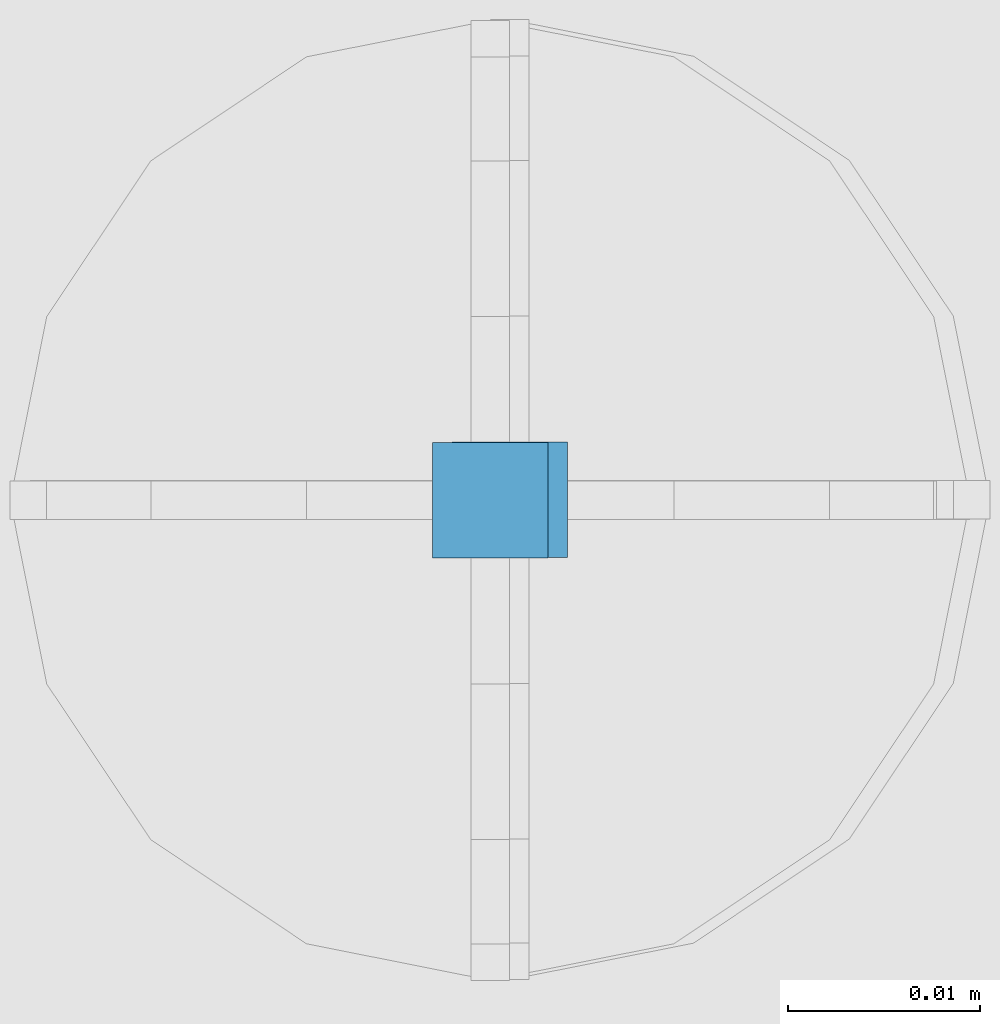
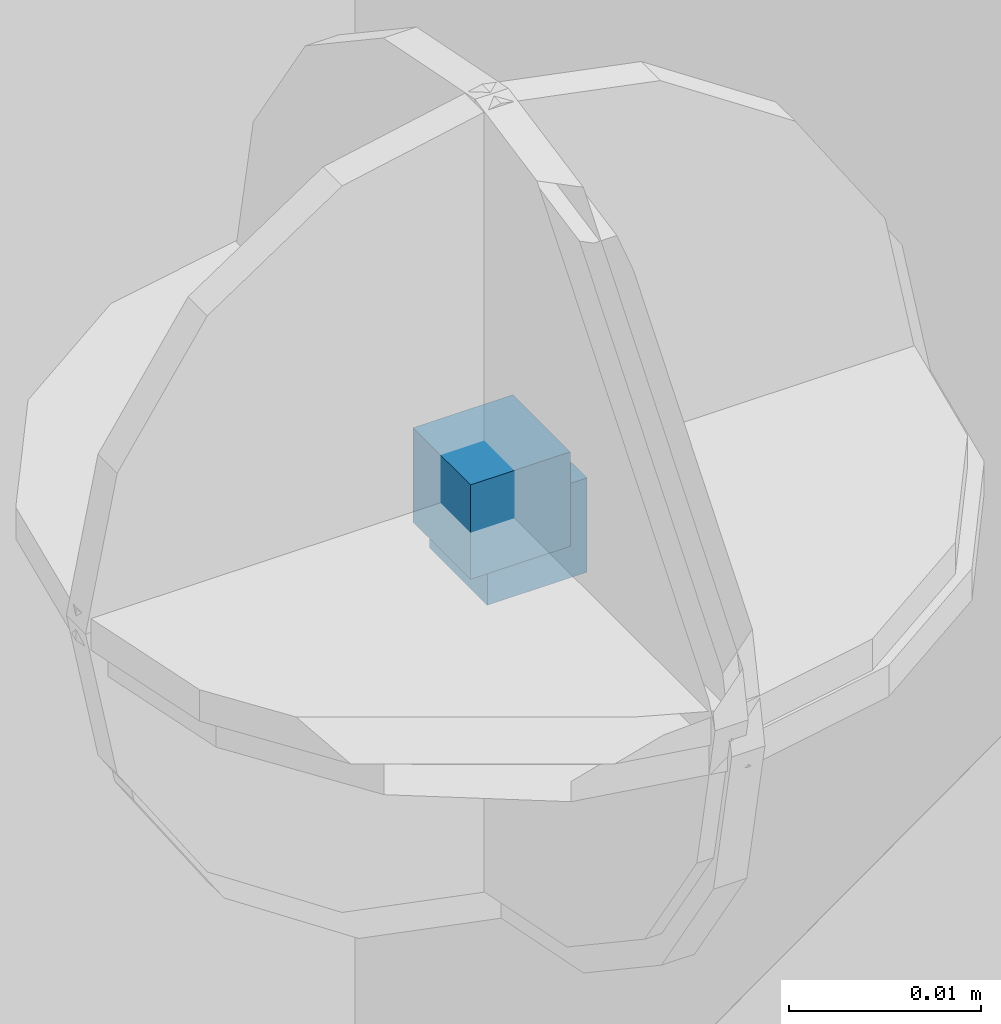
# One storey, part 75 of 349: 2 columns, 3 elements without a shape of their own.
"""IFC2X3 building model written with IfcOpenShell, lengths in millimetres."""

from ifc_helpers import new_model, si_unit, frame, origin_with_axes, place, context, subcontext, project, spatial, faceted_brep, material, type_object, element, aggregate, save


model = new_model("IFC2X3")

# Units and contexts
model_context = context("Model", 3, precision=1e-05, world=origin_with_axes())
body_context = subcontext(model_context, "Body", "Model", "MODEL_VIEW")
ifc_project = project(units=[si_unit("LENGTHUNIT", "METRE", prefix="MILLI"), si_unit("AREAUNIT", "SQUARE_METRE"), si_unit("VOLUMEUNIT", "CUBIC_METRE"), si_unit("MASSUNIT", "GRAM", prefix="KILO"), si_unit("TIMEUNIT", "SECOND"), si_unit("PLANEANGLEUNIT", "RADIAN"), si_unit("SOLIDANGLEUNIT", "STERADIAN"), si_unit("THERMODYNAMICTEMPERATUREUNIT", "DEGREE_CELSIUS"), si_unit("LUMINOUSINTENSITYUNIT", "LUMEN")], contexts=[model_context])

# Site, building, storey
site_placement = place(None, origin_with_axes())
site = spatial("IfcSite", under=ifc_project, at=site_placement, CompositionType="ELEMENT")
building_placement = place(site_placement, origin_with_axes())
building = spatial("IfcBuilding", under=site, at=building_placement, CompositionType="ELEMENT")
storey_placement = place(building_placement, origin_with_axes())
storey = spatial("IfcBuildingStorey", under=building, at=storey_placement, Name="4", CompositionType="ELEMENT", Elevation=0.0)

# Assemblies, columns
assembly_1_placement = place(storey_placement, origin_with_axes())
assembly_1 = element("IfcElementAssembly", 1, at=assembly_1_placement, inside=storey, AssemblyPlace="NOTDEFINED", PredefinedType="REINFORCEMENT_UNIT")
assembly_2_placement = place(assembly_1_placement, origin_with_axes())
assembly_2 = element("IfcElementAssembly", 2, at=assembly_2_placement, Name="Steel Assembly", AssemblyPlace="NOTDEFINED", PredefinedType="RIGID_FRAME")
ifc_material = material(Name="STEEL/Steel_Undefined")
column_type = type_object("IfcColumnType", PredefinedType="NOTDEFINED")
column_1_placement = place(assembly_2_placement, frame((19805.3672816511, 20613.5564077389, 93731.5262892386), z_axis=(0.0, -1.0, 0.0), x_axis=(0.0, 0.0, 1.0)))
column_1 = element("IfcColumn", 3, at=column_1_placement, type_object=column_type, material=ifc_material, Name="PP", context=body_context, shape_type="Brep", body=[
    faceted_brep([(0.0, 3.0, -3.0), (0.0, 2.99999999999636, 3.0), (6.0, 2.99999999999636, 3.0), (6.0, 3.0, -3.0), (0.0, -3.00000000000364, 3.0), (6.0, -3.00000000000364, 3.0), (0.0, -3.0, -3.0), (6.0, -3.0, -3.0)], [[[0, 1, 2, 3]], [[1, 4, 5, 2]], [[4, 6, 7, 5]], [[6, 0, 3, 7]], [[5, 7, 3, 2]], [[6, 4, 1, 0]]]),
])
aggregate(assembly_2, [column_1])
assembly_3_placement = place(assembly_1_placement, origin_with_axes())
assembly_3 = element("IfcElementAssembly", 4, at=assembly_3_placement, Name="Steel Assembly", AssemblyPlace="NOTDEFINED", PredefinedType="RIGID_FRAME")
aggregate(assembly_1, [assembly_2, assembly_3])
column_2_placement = place(assembly_3_placement, frame((19806.3888800542, 20613.5887932168, 93729.4935861413), z_axis=(0.0, -1.0, 0.0), x_axis=(0.0, 0.0, 1.0)))
column_2 = element("IfcColumn", 5, at=column_2_placement, type_object=column_type, material=ifc_material, Name="PP", context=body_context, shape_type="Brep", body=[
    faceted_brep([(0.0, 3.0, -3.0), (0.0, 2.99999999999636, 3.0), (6.0, 2.99999999999636, 3.0), (6.0, 3.0, -3.0), (0.0, -3.00000000000364, 3.0), (6.0, -3.00000000000364, 3.0), (0.0, -3.0, -3.0), (6.0, -3.0, -3.0)], [[[0, 1, 2, 3]], [[1, 4, 5, 2]], [[4, 6, 7, 5]], [[6, 0, 3, 7]], [[5, 7, 3, 2]], [[6, 4, 1, 0]]]),
])
aggregate(assembly_3, [column_2])

save(model, "model.ifc")
